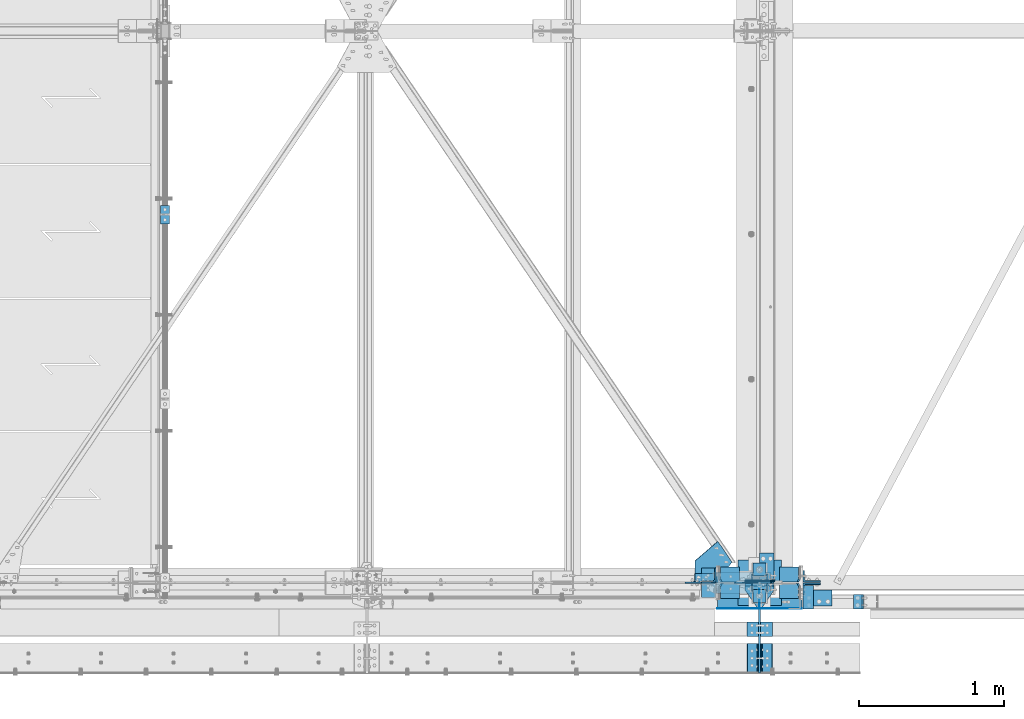
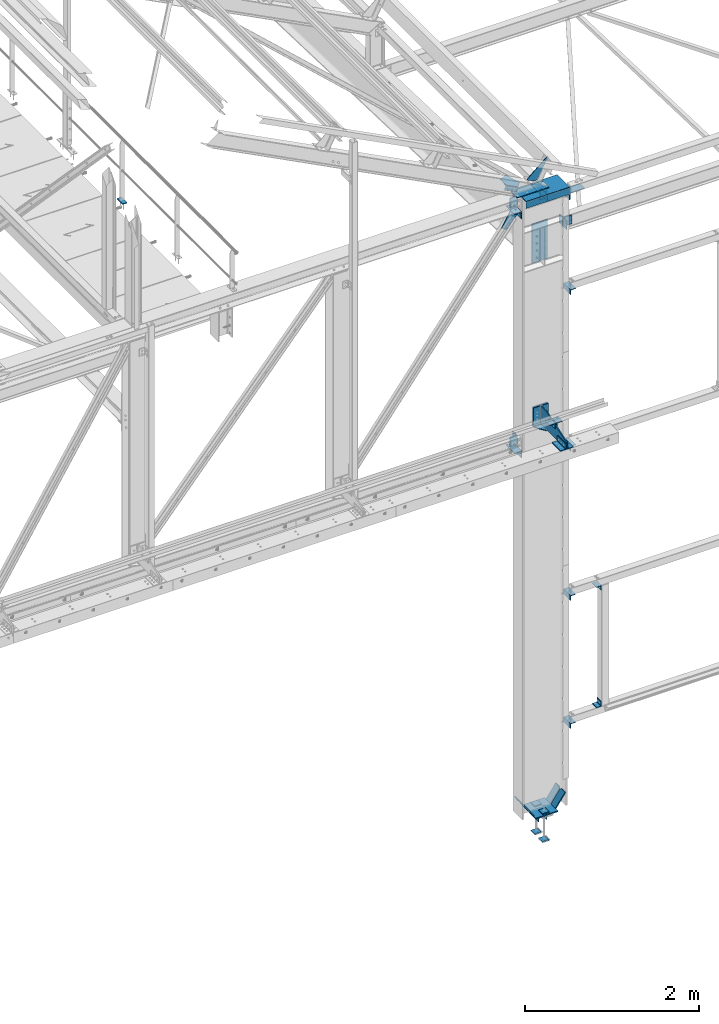
# One storey, part 87 of 496: 35 beams, 7 members, 28 elements without a shape of their own.
"""IFC2X3 building model written with IfcOpenShell, lengths in millimetres."""

from ifc_helpers import new_model, si_unit, frame, origin_with_axes, origin_2d_with_axis, place, context, subcontext, project, spatial, polyline, rectangle, i_section, l_section, outline, extrude, boolean, material, type_object, element, aggregate, save


model = new_model("IFC2X3")

# Units and contexts
model_context = context("Model", 3, precision=1e-05, world=origin_with_axes())
body_context = subcontext(model_context, "Body", "Model", "MODEL_VIEW")
ifc_project = project(units=[si_unit("LENGTHUNIT", "METRE", prefix="MILLI"), si_unit("AREAUNIT", "SQUARE_METRE"), si_unit("VOLUMEUNIT", "CUBIC_METRE"), si_unit("MASSUNIT", "GRAM", prefix="KILO"), si_unit("TIMEUNIT", "SECOND"), si_unit("PLANEANGLEUNIT", "RADIAN"), si_unit("SOLIDANGLEUNIT", "STERADIAN"), si_unit("THERMODYNAMICTEMPERATUREUNIT", "DEGREE_CELSIUS"), si_unit("LUMINOUSINTENSITYUNIT", "LUMEN")], contexts=[model_context])

# Site, building, storey
site_placement = place(None, origin_with_axes())
site = spatial("IfcSite", under=ifc_project, at=site_placement, CompositionType="ELEMENT")
building_placement = place(site_placement, origin_with_axes())
building = spatial("IfcBuilding", under=site, at=building_placement, Name="Undefined", CompositionType="ELEMENT")
storey_placement = place(building_placement, origin_with_axes())
storey = spatial("IfcBuildingStorey", under=building, at=storey_placement, Name="Undefined", CompositionType="ELEMENT", Elevation=0.0)

# Assembly, beam
assembly_1_placement = place(storey_placement, origin_with_axes())
assembly_1 = element("IfcElementAssembly", 1, at=assembly_1_placement, inside=storey, Name="MAIN COURANTE", AssemblyPlace="NOTDEFINED", PredefinedType="NOTDEFINED")
ifc_material_1 = material(Name="Undefined/S235-E24")
beam_type_1 = type_object("IfcBeamType", PredefinedType="NOTDEFINED")
beam_1_placement = place(assembly_1_placement, frame((24783.9915997864, 2600.00343957572, 8245.00000732384), z_axis=(-1.0, 0.0, 0.0), x_axis=(0.0, -1.0, 0.0)))
beam_1 = element("IfcBeam", 2, at=beam_1_placement, type_object=beam_type_1, material=ifc_material_1, context=body_context, shape_type="SweptSolid", body=[
    extrude(rectangle(XDim=10.0, YDim=60.0, at=origin_2d_with_axis()), frame((130.0, 0.0, 0.0), z_axis=(-1.0, 0.0, 0.0), x_axis=(0.0, -1.0, 0.0)), (0.0, 0.0, 1.0), 130.0),
])
aggregate(assembly_1, [beam_1])

assembly_2_placement = place(storey_placement, origin_with_axes())
assembly_2 = element("IfcElementAssembly", 3, at=assembly_2_placement, inside=storey, Name="CONTRE", AssemblyPlace="NOTDEFINED", PredefinedType="NOTDEFINED")
beam_type_2 = type_object("IfcBeamType", PredefinedType="NOTDEFINED")
beam_2_placement = place(assembly_2_placement, frame((28880.0, 11.0084493474315, 5479.99824538435), z_axis=(1.0, 0.0, 0.0), x_axis=(0.0, 0.0, -1.0)))
beam_2 = element("IfcBeam", 4, at=beam_2_placement, type_object=beam_type_2, material=ifc_material_1, Name="CONTRE", context=body_context, shape_type="SweptSolid", body=[
    extrude(rectangle(XDim=10.0, YDim=200.0, at=origin_2d_with_axis()), frame((264.997552749181, 0.0, 0.0), z_axis=(-1.0, 0.0, 0.0), x_axis=(0.0, -1.0, 0.0)), (0.0, 0.0, 1.0), 265.0),
])
aggregate(assembly_2, [beam_2])

assembly_3_placement = place(storey_placement, origin_with_axes())
assembly_3 = element("IfcElementAssembly", 5, at=assembly_3_placement, inside=storey, AssemblyPlace="NOTDEFINED", PredefinedType="NOTDEFINED")
beam_type_3 = type_object("IfcBeamType", PredefinedType="NOTDEFINED")
beam_3_placement = place(assembly_3_placement, frame((28927.4921676285, -270.0, 5409.99824538435), z_axis=(0.0, 0.0, -1.0), x_axis=(0.0, -1.0, 0.0)))
beam_3 = element("IfcBeam", 6, at=beam_3_placement, type_object=beam_type_3, material=ifc_material_1, context=body_context, shape_type="SweptSolid", body=[
    extrude(l_section(Depth=80.0, Width=80.0, Thickness=8.0, FilletRadius=10.0, EdgeRadius=5.0, at=origin_2d_with_axis()), frame((100.000000000021, 5.72981662116945e-11, -4.09272615797818e-12), z_axis=(-1.0, 0.0, 0.0), x_axis=(0.0, -1.0, 0.0)), (0.0, 0.0, 1.0), 100.0),
])
aggregate(assembly_3, [beam_3])

assembly_4_placement = place(storey_placement, origin_with_axes())
assembly_4 = element("IfcElementAssembly", 7, at=assembly_4_placement, inside=storey, AssemblyPlace="NOTDEFINED", PredefinedType="NOTDEFINED")
beam_4_placement = place(assembly_4_placement, frame((28832.5, -370.0, 5409.99824538435), z_axis=(0.0, 0.0, -1.0), x_axis=(0.0, 1.0, 0.0)))
beam_4 = element("IfcBeam", 8, at=beam_4_placement, type_object=beam_type_3, material=ifc_material_1, context=body_context, shape_type="SweptSolid", body=[
    extrude(l_section(Depth=80.0, Width=80.0, Thickness=8.0, FilletRadius=10.0, EdgeRadius=5.0, at=origin_2d_with_axis()), frame((100.000000000021, 5.72981662116945e-11, -4.09272615797818e-12), z_axis=(-1.0, 0.0, 0.0), x_axis=(0.0, -1.0, 0.0)), (0.0, 0.0, 1.0), 100.0),
])
aggregate(assembly_4, [beam_4])

assembly_5_placement = place(storey_placement, origin_with_axes())
assembly_5 = element("IfcElementAssembly", 9, at=assembly_5_placement, inside=storey, AssemblyPlace="NOTDEFINED", PredefinedType="NOTDEFINED")
beam_5_placement = place(assembly_5_placement, frame((28927.4921676285, -620.0, 5269.99824538435), z_axis=(0.0, 0.0, 1.0), x_axis=(0.0, 1.0, 0.0)))
beam_5 = element("IfcBeam", 10, at=beam_5_placement, type_object=beam_type_3, material=ifc_material_1, context=body_context, shape_type="SweptSolid", body=[
    extrude(l_section(Depth=80.0, Width=80.0, Thickness=8.0, FilletRadius=10.0, EdgeRadius=5.0, at=origin_2d_with_axis()), frame((200.0, 0.0, 0.0), z_axis=(-1.0, 0.0, 0.0), x_axis=(0.0, -1.0, 0.0)), (0.0, 0.0, 1.0), 200.0),
])
aggregate(assembly_5, [beam_5])

assembly_6_placement = place(storey_placement, origin_with_axes())
assembly_6 = element("IfcElementAssembly", 11, at=assembly_6_placement, inside=storey, AssemblyPlace="NOTDEFINED", PredefinedType="NOTDEFINED")
beam_6_placement = place(assembly_6_placement, frame((28832.5, -420.0, 5269.99824538435), z_axis=(0.0, 0.0, 1.0), x_axis=(0.0, -1.0, 0.0)))
beam_6 = element("IfcBeam", 12, at=beam_6_placement, type_object=beam_type_3, material=ifc_material_1, context=body_context, shape_type="SweptSolid", body=[
    extrude(l_section(Depth=80.0, Width=80.0, Thickness=8.0, FilletRadius=10.0, EdgeRadius=5.0, at=origin_2d_with_axis()), frame((200.0, 0.0, 0.0), z_axis=(-1.0, 0.0, 0.0), x_axis=(0.0, -1.0, 0.0)), (0.0, 0.0, 1.0), 200.0),
])
aggregate(assembly_6, [beam_6])

# Assembly, beams
assembly_7_placement = place(storey_placement, origin_with_axes())
assembly_7 = element("IfcElementAssembly", 13, at=assembly_7_placement, inside=storey, Name="CONSOLE", AssemblyPlace="NOTDEFINED", PredefinedType="NOTDEFINED")
beam_type_4 = type_object("IfcBeamType", PredefinedType="NOTDEFINED")
beam_7_placement = place(assembly_7_placement, frame((28780.0, -20.9999999999999, 5224.99824534403), z_axis=(0.0, 0.0, 1.0), x_axis=(0.0, -1.0, 0.0)))
beam_7 = element("IfcBeam", 14, at=beam_7_placement, type_object=beam_type_4, material=ifc_material_1, context=body_context, shape_type="SweptSolid", body=[
    extrude(outline(polyline([(0.0, 0.0), (30.0, 0.0), (149.0, 82.5), (149.0, 117.5), (30.0, 200.0), (0.0, 200.0), (0.0, 0.0)])), frame((0.0, 0.0, -5.0), z_axis=(0.0, 0.0, 1.0), x_axis=(1.0, 0.0, 0.0)), (0.0, 0.0, 1.0), 10.0),
])
beam_type_5 = type_object("IfcBeamType", PredefinedType="NOTDEFINED")
beam_8_placement = place(assembly_7_placement, frame((28880.0, -13.4999999999999, 5479.99824538435), z_axis=(1.0, 0.0, 0.0), x_axis=(0.0, 0.0, -1.0)))
beam_8 = element("IfcBeam", 15, at=beam_8_placement, type_object=beam_type_5, material=ifc_material_1, context=body_context, shape_type="SweptSolid", body=[
    extrude(rectangle(XDim=15.0, YDim=200.0, at=origin_2d_with_axis()), frame((264.997552749181, 0.0, 0.0), z_axis=(-1.0, 0.0, 0.0), x_axis=(0.0, -1.0, 0.0)), (0.0, 0.0, 1.0), 265.0),
])
beam_type_6 = type_object("IfcBeamType", PredefinedType="NOTDEFINED")
beam_9_placement = place(assembly_7_placement, frame((28880.0, -620.0, 5229.99824538435), z_axis=(-1.0, 0.0, 0.0), x_axis=(0.0, 0.0, 1.0)))
beam_9 = element("IfcBeam", 16, at=beam_9_placement, type_object=beam_type_6, material=ifc_material_1, Name="CONSOLE", context=body_context, shape_type="SweptSolid", body=[
    extrude(outline(polyline([(0.0, 0.0), (100.0, 0.0), (250.0, 450.0), (250.0, 599.0), (19.9999999424381, 599.0), (-5.56399857962367e-08, 579.0), (0.0, 0.0)])), frame((0.0, 0.0, -7.5), z_axis=(0.0, 0.0, 1.0), x_axis=(1.0, 0.0, 0.0)), (0.0, 0.0, 1.0), 15.0),
])
aggregate(assembly_7, [beam_7, beam_8, beam_9])

# Assembly, beam
assembly_8_placement = place(storey_placement, origin_with_axes())
assembly_8 = element("IfcElementAssembly", 17, at=assembly_8_placement, inside=storey, AssemblyPlace="NOTDEFINED", PredefinedType="NOTDEFINED")
beam_type_7 = type_object("IfcBeamType", PredefinedType="NOTDEFINED")
beam_10_placement = place(assembly_8_placement, frame((29215.0012714194, -20.0000002019504, 964.996098044679), z_axis=(0.0, 0.0, -1.0), x_axis=(0.0, -1.0, 0.0)))
beam_10 = element("IfcBeam", 18, at=beam_10_placement, type_object=beam_type_7, material=ifc_material_1, context=body_context, shape_type="SweptSolid", body=[
    extrude(l_section(Depth=70.0, Width=70.0, Thickness=7.0, FilletRadius=9.0, EdgeRadius=4.5, at=origin_2d_with_axis()), frame((160.000008264571, 0.0, 0.0), z_axis=(-1.0, 0.0, 0.0), x_axis=(0.0, -1.0, 0.0)), (0.0, 0.0, 1.0), 160.0),
])
aggregate(assembly_8, [beam_10])

assembly_9_placement = place(storey_placement, origin_with_axes())
assembly_9 = element("IfcElementAssembly", 19, at=assembly_9_placement, inside=storey, AssemblyPlace="NOTDEFINED", PredefinedType="NOTDEFINED")
beam_11_placement = place(assembly_9_placement, frame((29215.0012287166, -20.0000002019504, 7064.99609804556), z_axis=(0.0, 0.0, -1.0), x_axis=(0.0, -1.0, 0.0)))
beam_11 = element("IfcBeam", 20, at=beam_11_placement, type_object=beam_type_7, material=ifc_material_1, context=body_context, shape_type="SweptSolid", body=[
    extrude(l_section(Depth=70.0, Width=70.0, Thickness=7.0, FilletRadius=9.0, EdgeRadius=4.5, at=origin_2d_with_axis()), frame((160.000008264571, 0.0, 0.0), z_axis=(-1.0, 0.0, 0.0), x_axis=(0.0, -1.0, 0.0)), (0.0, 0.0, 1.0), 160.0),
])
aggregate(assembly_9, [beam_11])

assembly_10_placement = place(storey_placement, origin_with_axes())
assembly_10 = element("IfcElementAssembly", 21, at=assembly_10_placement, inside=storey, AssemblyPlace="NOTDEFINED", PredefinedType="NOTDEFINED")
beam_12_placement = place(assembly_10_placement, frame((29215.0012588166, -20.0000002019504, 2764.99609804556), z_axis=(0.0, 0.0, -1.0), x_axis=(0.0, -1.0, 0.0)))
beam_12 = element("IfcBeam", 22, at=beam_12_placement, type_object=beam_type_7, material=ifc_material_1, context=body_context, shape_type="SweptSolid", body=[
    extrude(l_section(Depth=70.0, Width=70.0, Thickness=7.0, FilletRadius=9.0, EdgeRadius=4.5, at=origin_2d_with_axis()), frame((160.000008264571, 0.0, 0.0), z_axis=(-1.0, 0.0, 0.0), x_axis=(0.0, -1.0, 0.0)), (0.0, 0.0, 1.0), 160.0),
])
aggregate(assembly_10, [beam_12])

assembly_11_placement = place(storey_placement, origin_with_axes())
assembly_11 = element("IfcElementAssembly", 23, at=assembly_11_placement, inside=storey, AssemblyPlace="NOTDEFINED", PredefinedType="NOTDEFINED")
beam_13_placement = place(assembly_11_placement, frame((29215.0012588166, -20.0000002019504, 4864.99609804556), z_axis=(0.0, 0.0, -1.0), x_axis=(0.0, -1.0, 0.0)))
beam_13 = element("IfcBeam", 24, at=beam_13_placement, type_object=beam_type_7, material=ifc_material_1, context=body_context, shape_type="SweptSolid", body=[
    extrude(l_section(Depth=70.0, Width=70.0, Thickness=7.0, FilletRadius=9.0, EdgeRadius=4.5, at=origin_2d_with_axis()), frame((160.000008264571, 0.0, 0.0), z_axis=(-1.0, 0.0, 0.0), x_axis=(0.0, -1.0, 0.0)), (0.0, 0.0, 1.0), 160.0),
])
aggregate(assembly_11, [beam_13])

assembly_12_placement = place(storey_placement, origin_with_axes())
assembly_12 = element("IfcElementAssembly", 25, at=assembly_12_placement, inside=storey, AssemblyPlace="NOTDEFINED", PredefinedType="NOTDEFINED")
beam_14_placement = place(assembly_12_placement, frame((29559.999999988, -80.0000086005748, 1135.0), z_axis=(0.0, 0.0, 1.0), x_axis=(0.0, -1.0, 0.0)))
beam_14 = element("IfcBeam", 26, at=beam_14_placement, type_object=beam_type_7, material=ifc_material_1, context=body_context, shape_type="SweptSolid", body=[
    extrude(l_section(Depth=70.0, Width=70.0, Thickness=7.0, FilletRadius=9.0, EdgeRadius=4.5, at=origin_2d_with_axis()), frame((100.000000000021, 5.72981662116945e-11, -4.09272615797818e-12), z_axis=(-1.0, 0.0, 0.0), x_axis=(0.0, -1.0, 0.0)), (0.0, 0.0, 1.0), 100.0),
])
aggregate(assembly_12, [beam_14])

assembly_13_placement = place(storey_placement, origin_with_axes())
assembly_13 = element("IfcElementAssembly", 27, at=assembly_13_placement, inside=storey, AssemblyPlace="NOTDEFINED", PredefinedType="NOTDEFINED")
beam_15_placement = place(assembly_13_placement, frame((29560.000000988, -180.000008614613, 2765.0), z_axis=(0.0, 0.0, -1.0), x_axis=(0.0, 1.0, 0.0)))
beam_15 = element("IfcBeam", 28, at=beam_15_placement, type_object=beam_type_7, material=ifc_material_1, context=body_context, shape_type="SweptSolid", body=[
    extrude(l_section(Depth=70.0, Width=70.0, Thickness=7.0, FilletRadius=9.0, EdgeRadius=4.5, at=origin_2d_with_axis()), frame((100.000000000021, 5.72981662116945e-11, -4.09272615797818e-12), z_axis=(-1.0, 0.0, 0.0), x_axis=(0.0, -1.0, 0.0)), (0.0, 0.0, 1.0), 100.0),
])
aggregate(assembly_13, [beam_15])

# Assembly, member
assembly_14_placement = place(storey_placement, origin_with_axes())
assembly_14 = element("IfcElementAssembly", 29, at=assembly_14_placement, inside=storey, AssemblyPlace="NOTDEFINED", PredefinedType="NOTDEFINED")
member_type_1 = type_object("IfcMemberType", PredefinedType="NOTDEFINED")
member_1_placement = place(assembly_14_placement, frame((28579.3252498457, 33.0001377978096, 8604.45371099686), z_axis=(0.0, 1.0, 0.0), x_axis=(-0.887870970350137, -2.80000019972605e-08, 0.460092534181446)))
member_1 = element("IfcMember", 30, at=member_1_placement, type_object=member_type_1, material=ifc_material_1, context=body_context, shape_type="SweptSolid", body=[
    extrude(l_section(Depth=60.0, Width=60.0, Thickness=6.0, FilletRadius=8.0, EdgeRadius=4.0, at=origin_2d_with_axis()), frame((180.0, 0.0, 0.0), z_axis=(-1.0, 0.0, 0.0), x_axis=(0.0, -1.0, 0.0)), (0.0, 0.0, 1.0), 180.0),
])
aggregate(assembly_14, [member_1])

# Assembly, beam
assembly_15_placement = place(storey_placement, origin_with_axes())
assembly_15 = element("IfcElementAssembly", 31, at=assembly_15_placement, inside=storey, Name="SHED", AssemblyPlace="NOTDEFINED", PredefinedType="NOTDEFINED")
beam_type_8 = type_object("IfcBeamType", PredefinedType="NOTDEFINED")
beam_16_placement = place(assembly_15_placement, frame((28714.4895719006, 0.0, 8721.3758937839), z_axis=(0.0, -1.0, 0.0), x_axis=(-0.460093241820242, 0.0, -0.887870603653112)))
beam_16 = element("IfcBeam", 32, at=beam_16_placement, type_object=beam_type_8, material=ifc_material_1, context=body_context, shape_type="SweptSolid", body=[
    extrude(outline(polyline([(0.0, 0.0), (20.0, 0.0), (20.0000000002019, 109.999999999982), (-9.99999999974731, 139.99998998623), (-300.0000000002, 139.999893186625), (-300.000000000226, 119.999893186643), (0.0, 0.0)])), frame((0.0, 0.0, -4.0), z_axis=(0.0, 0.0, 1.0), x_axis=(1.0, 0.0, 0.0)), (0.0, 0.0, 1.0), 8.0),
])
aggregate(assembly_15, [beam_16])

assembly_16_placement = place(storey_placement, origin_with_axes())
assembly_16 = element("IfcElementAssembly", 33, at=assembly_16_placement, inside=storey, AssemblyPlace="NOTDEFINED", PredefinedType="NOTDEFINED")
beam_type_9 = type_object("IfcBeamType", PredefinedType="NOTDEFINED")
beam_17_placement = place(assembly_16_placement, frame((29280.0031155658, -159.989858491889, 8399.99872306502), z_axis=(0.999999994849078, 0.000101497999992432, 0.0), x_axis=(-0.000101497999992439, 0.999999994849078, 0.0)))
beam_17 = element("IfcBeam", 34, at=beam_17_placement, type_object=beam_type_9, material=ifc_material_1, context=body_context, shape_type="SweptSolid", body=[
    extrude(l_section(Depth=200.0, Width=100.0, Thickness=10.0, FilletRadius=15.0, EdgeRadius=7.5, at=origin_2d_with_axis()), frame((109.999999008529, 1.81898940354586e-12, 0.0), z_axis=(-1.0, 0.0, 0.0), x_axis=(0.0, -1.0, 0.0)), (0.0, 0.0, 1.0), 110.0),
])
aggregate(assembly_16, [beam_17])

assembly_17_placement = place(storey_placement, origin_with_axes())
assembly_17 = element("IfcElementAssembly", 35, at=assembly_17_placement, inside=storey, AssemblyPlace="NOTDEFINED", PredefinedType="NOTDEFINED")
beam_18_placement = place(assembly_17_placement, frame((28980.0, 106.0, 8400.0), z_axis=(0.0, 1.0, 0.0), x_axis=(-1.0, 0.0, 0.0)))
beam_18 = element("IfcBeam", 36, at=beam_18_placement, type_object=beam_type_9, material=ifc_material_1, context=body_context, shape_type="SweptSolid", body=[
    extrude(l_section(Depth=200.0, Width=100.0, Thickness=10.0, FilletRadius=15.0, EdgeRadius=7.5, at=origin_2d_with_axis()), frame((100.000000000021, 5.72981662116945e-11, -4.09272615797818e-12), z_axis=(-1.0, 0.0, 0.0), x_axis=(0.0, -1.0, 0.0)), (0.0, 0.0, 1.0), 100.0),
])
aggregate(assembly_17, [beam_18])

assembly_18_placement = place(storey_placement, origin_with_axes())
assembly_18 = element("IfcElementAssembly", 37, at=assembly_18_placement, inside=storey, Name="TRAVERSE", AssemblyPlace="NOTDEFINED", PredefinedType="NOTDEFINED")
beam_type_10 = type_object("IfcBeamType", PredefinedType="NOTDEFINED")
beam_19_placement = place(assembly_18_placement, frame((28880.0, 13.5, 8049.34004841314), z_axis=(-1.0, 0.0, 0.0), x_axis=(0.0, 0.0, -1.0)))
beam_19 = element("IfcBeam", 38, at=beam_19_placement, type_object=beam_type_10, material=ifc_material_1, context=body_context, shape_type="SweptSolid", body=[
    extrude(rectangle(XDim=15.0, YDim=210.0, at=origin_2d_with_axis()), frame((550.00003132, 0.0, 0.0), z_axis=(-1.0, 0.0, 0.0), x_axis=(0.0, -1.0, 0.0)), (0.0, 0.0, 1.0), 550.0),
])
aggregate(assembly_18, [beam_19])

assembly_19_placement = place(storey_placement, origin_with_axes())
assembly_19 = element("IfcElementAssembly", 39, at=assembly_19_placement, inside=storey, AssemblyPlace="NOTDEFINED", PredefinedType="NOTDEFINED")
beam_type_11 = type_object("IfcBeamType", PredefinedType="NOTDEFINED")
beam_20_placement = place(assembly_19_placement, frame((28591.4170141715, 285.322059221975, 8635.3552464622), z_axis=(-0.460093241820242, 0.0, -0.887870603653112), x_axis=(0.538249849949882, -0.795292763925977, -0.278920272974034)))
beam_20 = element("IfcBeam", 40, at=beam_20_placement, type_object=beam_type_11, material=ifc_material_1, context=body_context, shape_type="SweptSolid", body=[
    extrude(outline(polyline([(0.0, 0.0), (180.000000001455, -5.27506927028298e-10), (218.686340331524, 162.319595336492), (109.565696714972, 305.472290039921), (-9.36748074309435e-06, 221.953918457995), (0.0, 0.0)])), frame((0.0, 0.0, -3.0), z_axis=(0.0, 0.0, 1.0), x_axis=(1.0, 0.0, 0.0)), (0.0, 0.0, 1.0), 6.0),
])
aggregate(assembly_19, [beam_20])

assembly_20_placement = place(storey_placement, origin_with_axes())
assembly_20 = element("IfcElementAssembly", 41, at=assembly_20_placement, inside=storey, Name="TRAVERSE SHED", AssemblyPlace="NOTDEFINED", PredefinedType="NOTDEFINED")
beam_type_12 = type_object("IfcBeamType", PredefinedType="NOTDEFINED")
beam_21_placement = place(assembly_20_placement, frame((28743.3573802739, 74.9996843547758, 8554.99999999943), z_axis=(-1.0, 0.0, 0.0), x_axis=(0.0, -1.0, 0.0)))
beam_21 = element("IfcBeam", 42, at=beam_21_placement, type_object=beam_type_12, material=ifc_material_1, context=body_context, shape_type="SweptSolid", body=[
    extrude(rectangle(XDim=10.0, YDim=420.0, at=origin_2d_with_axis()), frame((149.999995982835, 4.54747350886464e-12, 3.63797880709171e-12), z_axis=(-1.0, 0.0, 0.0), x_axis=(0.0, -1.0, 0.0)), (0.0, 0.0, 1.0), 150.0),
])
aggregate(assembly_20, [beam_21])

# Assembly, member
assembly_21_placement = place(storey_placement, origin_with_axes())
assembly_21 = element("IfcElementAssembly", 43, at=assembly_21_placement, inside=storey, AssemblyPlace="NOTDEFINED", PredefinedType="NOTDEFINED")
member_type_2 = type_object("IfcMemberType", PredefinedType="NOTDEFINED")
member_2_placement = place(assembly_21_placement, frame((29240.0021442314, 41.0926894995976, 7888.6330271737), z_axis=(1.0, 0.0, 0.0), x_axis=(0.0, 0.031410887010906, 0.999506556345274)))
member_2 = element("IfcMember", 44, at=member_2_placement, type_object=member_type_2, material=ifc_material_1, context=body_context, shape_type="SweptSolid", body=[
    extrude(l_section(Depth=120.0, Width=80.0, Thickness=10.0, FilletRadius=11.0, EdgeRadius=5.5, at=origin_2d_with_axis()), frame((120.0, 0.0, 0.0), z_axis=(-1.0, 0.0, 0.0), x_axis=(0.0, -1.0, 0.0)), (0.0, 0.0, 1.0), 120.0),
])
aggregate(assembly_21, [member_2])

assembly_22_placement = place(storey_placement, origin_with_axes())
assembly_22 = element("IfcElementAssembly", 45, at=assembly_22_placement, inside=storey, AssemblyPlace="NOTDEFINED", PredefinedType="NOTDEFINED")
member_3_placement = place(assembly_22_placement, frame((29240.0021442313, -41.096389158032, 8011.27520452147), z_axis=(1.0, 0.0, 0.0), x_axis=(0.0, -0.031410887010906, -0.999506556345274)))
member_3 = element("IfcMember", 46, at=member_3_placement, type_object=member_type_2, material=ifc_material_1, context=body_context, shape_type="SweptSolid", body=[
    extrude(l_section(Depth=120.0, Width=80.0, Thickness=10.0, FilletRadius=11.0, EdgeRadius=5.5, at=origin_2d_with_axis()), frame((120.0, 0.0, 0.0), z_axis=(-1.0, 0.0, 0.0), x_axis=(0.0, -1.0, 0.0)), (0.0, 0.0, 1.0), 120.0),
])
aggregate(assembly_22, [member_3])

# Assembly, beam
assembly_23_placement = place(storey_placement, origin_with_axes())
assembly_23 = element("IfcElementAssembly", 47, at=assembly_23_placement, inside=storey, AssemblyPlace="NOTDEFINED", PredefinedType="NOTDEFINED")
beam_type_13 = type_object("IfcBeamType", PredefinedType="NOTDEFINED")
beam_22_placement = place(assembly_23_placement, frame((28529.9999062433, 53.500000000834, 8520.00002208745), z_axis=(-1.0, 0.0, 0.0), x_axis=(0.0, 0.0, -1.0)))
beam_22 = element("IfcBeam", 48, at=beam_22_placement, type_object=beam_type_13, material=ifc_material_1, context=body_context, shape_type="SweptSolid", body=[
    extrude(l_section(Depth=100.0, Width=100.0, Thickness=10.0, FilletRadius=12.0, EdgeRadius=6.0, at=origin_2d_with_axis()), frame((130.0, 0.0, 0.0), z_axis=(-1.0, 0.0, 0.0), x_axis=(0.0, -1.0, 0.0)), (0.0, 0.0, 1.0), 130.0),
])
aggregate(assembly_23, [beam_22])

assembly_24_placement = place(storey_placement, origin_with_axes())
assembly_24 = element("IfcElementAssembly", 49, at=assembly_24_placement, inside=storey, AssemblyPlace="NOTDEFINED", PredefinedType="NOTDEFINED")
beam_23_placement = place(assembly_24_placement, frame((28529.9960922515, -99.9992396415795, 8309.99916813909), z_axis=(0.0, 0.0, -1.0), x_axis=(1.5290000004067e-05, 0.999999999883108, 0.0)))
beam_23 = element("IfcBeam", 50, at=beam_23_placement, type_object=beam_type_13, material=ifc_material_1, context=body_context, shape_type="SweptSolid", body=[
    extrude(l_section(Depth=100.0, Width=100.0, Thickness=10.0, FilletRadius=12.0, EdgeRadius=6.0, at=origin_2d_with_axis()), frame((200.0, 0.0, 0.0), z_axis=(-1.0, 0.0, 0.0), x_axis=(0.0, -1.0, 0.0)), (0.0, 0.0, 1.0), 200.0),
])

assembly_25_placement = place(storey_placement, origin_with_axes())
assembly_25 = element("IfcElementAssembly", 51, at=assembly_25_placement, inside=storey, AssemblyPlace="NOTDEFINED", PredefinedType="NOTDEFINED")
beam_24_placement = place(assembly_25_placement, frame((28529.9999062433, 53.500000000834, 5160.00085394835), z_axis=(-1.0, 0.0, 0.0), x_axis=(0.0, 0.0, -1.0)))
beam_24 = element("IfcBeam", 52, at=beam_24_placement, type_object=beam_type_13, material=ifc_material_1, context=body_context, shape_type="SweptSolid", body=[
    extrude(l_section(Depth=100.0, Width=100.0, Thickness=10.0, FilletRadius=12.0, EdgeRadius=6.0, at=origin_2d_with_axis()), frame((130.0, 0.0, 0.0), z_axis=(-1.0, 0.0, 0.0), x_axis=(0.0, -1.0, 0.0)), (0.0, 0.0, 1.0), 130.0),
])
aggregate(assembly_25, [beam_24])

assembly_26_placement = place(storey_placement, origin_with_axes())
assembly_26 = element("IfcElementAssembly", 53, at=assembly_26_placement, inside=storey, AssemblyPlace="NOTDEFINED", PredefinedType="NOTDEFINED")
beam_25_placement = place(assembly_26_placement, frame((28529.9960922515, -99.9992396415795, 4950.0), z_axis=(0.0, 0.0, -1.0), x_axis=(1.5290000004067e-05, 0.999999999883108, 0.0)))
beam_25 = element("IfcBeam", 54, at=beam_25_placement, type_object=beam_type_13, material=ifc_material_1, context=body_context, shape_type="SweptSolid", body=[
    extrude(l_section(Depth=100.0, Width=100.0, Thickness=10.0, FilletRadius=12.0, EdgeRadius=6.0, at=origin_2d_with_axis()), frame((200.0, 0.0, 0.0), z_axis=(-1.0, 0.0, 0.0), x_axis=(0.0, -1.0, 0.0)), (0.0, 0.0, 1.0), 200.0),
])
aggregate(assembly_26, [beam_25])

# Beam
beam_type_14 = type_object("IfcBeamType", PredefinedType="NOTDEFINED")
beam_26_placement = place(assembly_24_placement, frame((28569.9960922468, 0.0, 8259.99916813909), z_axis=(0.0, -1.0, 0.0), x_axis=(0.0, 0.0, 1.0)))
beam_26 = element("IfcBeam", 55, at=beam_26_placement, type_object=beam_type_14, material=ifc_material_1, context=body_context, shape_type="SweptSolid", body=[
    extrude(outline(polyline([(0.0, 0.0), (70.0, 0.0), (90.0, 20.0), (90.0, 90.0), (-114.824501037598, 203.191070556641), (-163.177642822266, 139.457458496094), (0.0, 0.0)])), frame((0.0, 0.0, -4.0), z_axis=(0.0, 0.0, 1.0), x_axis=(1.0, 0.0, 0.0)), (0.0, 0.0, 1.0), 8.0),
])

aggregate(assembly_24, [beam_26, beam_23])

# Assembly, beams
assembly_27_placement = place(storey_placement, origin_with_axes())
assembly_27 = element("IfcElementAssembly", 56, at=assembly_27_placement, inside=storey, Name="PS24", AssemblyPlace="NOTDEFINED", PredefinedType="NOTDEFINED")
beam_type_15 = type_object("IfcBeamType", PredefinedType="NOTDEFINED")
beam_27_placement = place(assembly_27_placement, frame((28925.0, -45.0028495552906, -177.5), z_axis=(0.0, 0.0, 1.0), x_axis=(-1.0, 0.0, 0.0)))
beam_27 = element("IfcBeam", 57, at=beam_27_placement, type_object=beam_type_15, material=ifc_material_1, context=body_context, shape_type="SweptSolid", body=[
    extrude(outline(polyline([(0.0, 0.0), (90.0, 0.0), (90.0, 90.0), (0.0, 90.0), (0.0, 0.0)])), frame((0.0, 0.0, -7.5), z_axis=(0.0, 0.0, 1.0), x_axis=(1.0, 0.0, 0.0)), (0.0, 0.0, 1.0), 15.0),
])
beam_28_placement = place(assembly_27_placement, frame((28925.0, 134.997150444709, -177.5), z_axis=(0.0, 0.0, 1.0), x_axis=(-1.0, 0.0, 0.0)))
beam_28 = element("IfcBeam", 58, at=beam_28_placement, type_object=beam_type_15, material=ifc_material_1, context=body_context, shape_type="SweptSolid", body=[
    extrude(outline(polyline([(0.0, 0.0), (90.0, 0.0), (90.0, 90.0), (0.0, 90.0), (0.0, 0.0)])), frame((0.0, 0.0, -7.5), z_axis=(0.0, 0.0, 1.0), x_axis=(1.0, 0.0, 0.0)), (0.0, 0.0, 1.0), 15.0),
])
beam_29_placement = place(assembly_27_placement, frame((28925.0, -45.0028495552906, -572.5), z_axis=(0.0, 0.0, 1.0), x_axis=(-1.0, 0.0, 0.0)))
beam_29 = element("IfcBeam", 59, at=beam_29_placement, type_object=beam_type_15, material=ifc_material_1, context=body_context, shape_type="SweptSolid", body=[
    extrude(outline(polyline([(0.0, 0.0), (90.0, 0.0), (90.0, 90.0), (0.0, 90.0), (0.0, 0.0)])), frame((0.0, 0.0, -7.5), z_axis=(0.0, 0.0, 1.0), x_axis=(1.0, 0.0, 0.0)), (0.0, 0.0, 1.0), 15.0),
])
beam_30_placement = place(assembly_27_placement, frame((28925.0, 134.997150444709, -572.5), z_axis=(0.0, 0.0, 1.0), x_axis=(-1.0, 0.0, 0.0)))
beam_30 = element("IfcBeam", 60, at=beam_30_placement, type_object=beam_type_15, material=ifc_material_1, context=body_context, shape_type="SweptSolid", body=[
    extrude(outline(polyline([(0.0, 0.0), (90.0, 0.0), (90.0, 90.0), (0.0, 90.0), (0.0, 0.0)])), frame((0.0, 0.0, -7.5), z_axis=(0.0, 0.0, 1.0), x_axis=(1.0, 0.0, 0.0)), (0.0, 0.0, 1.0), 15.0),
])

assembly_28_placement = place(storey_placement, origin_with_axes())
assembly_28 = element("IfcElementAssembly", 61, at=assembly_28_placement, inside=storey, Name="POTEAU", AssemblyPlace="NOTDEFINED", PredefinedType="NOTDEFINED")
beam_type_16 = type_object("IfcBeamType", PredefinedType="NOTDEFINED")
beam_31_placement = place(assembly_28_placement, frame((28880.0, -6.5, 8450.0), z_axis=(-1.0, 0.0, 0.0), x_axis=(0.0, -1.0, 0.0)))
beam_31 = element("IfcBeam", 62, at=beam_31_placement, type_object=beam_type_16, material=ifc_material_1, context=body_context, shape_type="SweptSolid", body=[
    extrude(outline(polyline([(0.0, 0.0), (168.0, 0.0), (168.0, 70.0), (148.0, 90.0), (20.000000000001, 90.0), (-7.90371359471465e-08, 70.000007629249), (0.0, 0.0)])), frame((0.0, 0.0, -2.5), z_axis=(0.0, 0.0, 1.0), x_axis=(1.0, 0.0, 0.0)), (0.0, 0.0, 1.0), 5.0),
])
beam_type_17 = type_object("IfcBeamType", PredefinedType="NOTDEFINED")
beam_32_placement = place(assembly_28_placement, frame((28879.9999999836, -177.5, 8540.00000000232), z_axis=(1.0, 0.0, 0.0), x_axis=(0.0, 0.0, -1.0)))
beam_32 = element("IfcBeam", 63, at=beam_32_placement, type_object=beam_type_17, material=ifc_material_1, context=body_context, shape_type="SweptSolid", body=[
    extrude(rectangle(XDim=5.0, YDim=581.0, at=origin_2d_with_axis()), frame((90.0, 0.0, 0.0), z_axis=(-1.0, 0.0, 0.0), x_axis=(0.0, -1.0, 0.0)), (0.0, 0.0, 1.0), 90.0),
])
beam_type_18 = type_object("IfcBeamType", PredefinedType="NOTDEFINED")
beam_33_placement = place(assembly_28_placement, frame((28589.5, -35.0, 8545.0), z_axis=(0.0, 1.0, 0.0), x_axis=(1.0, 0.0, 0.0)))
beam_33 = element("IfcBeam", 64, at=beam_33_placement, type_object=beam_type_18, material=ifc_material_1, context=body_context, shape_type="SweptSolid", body=[
    extrude(rectangle(XDim=10.0, YDim=290.0, at=origin_2d_with_axis()), frame((581.0, 0.0, 0.0), z_axis=(-1.0, 0.0, 0.0), x_axis=(0.0, -1.0, 0.0)), (0.0, 0.0, 1.0), 581.0),
])

# Beam
ifc_material_2 = material(Name="Undefined/S275-E28")
beam_type_19 = type_object("IfcBeamType", Name="HEA120", PredefinedType="NOTDEFINED")
beam_34_placement = place(assembly_27_placement, frame((28879.99999991, 0.0, -210.0), z_axis=(-1.0, 0.0, 0.0), x_axis=(0.0, 0.0, -1.0)))
beam_34 = element("IfcBeam", 65, at=beam_34_placement, type_object=beam_type_19, material=ifc_material_2, ObjectType="HEA120", context=body_context, shape_type="SweptSolid", body=[
    extrude(i_section(OverallWidth=120.0, OverallDepth=114.0, WebThickness=5.0, FlangeThickness=8.0, FilletRadius=12.0, at=origin_2d_with_axis()), frame((120.0, 0.0, 0.0), z_axis=(-1.0, 0.0, 0.0), x_axis=(0.0, -1.0, 0.0)), (0.0, 0.0, 1.0), 120.0),
])

aggregate(assembly_27, [beam_34, beam_27, beam_28, beam_29, beam_30])

# Member
member_type_3 = type_object("IfcMemberType", PredefinedType="NOTDEFINED")
member_4_placement = place(assembly_28_placement, frame((29154.8763336431, 58.25, 4.33415056396631), z_axis=(0.0, 1.0, 0.0), x_axis=(-0.577886741942777, 0.0, -0.816116972919178)))
member_4 = element("IfcMember", 66, at=member_4_placement, type_object=member_type_3, material=ifc_material_1, context=body_context, shape_type="CSG", body=[
    boolean("DIFFERENCE", extrude(rectangle(XDim=15.0, YDim=103.5, at=origin_2d_with_axis()), frame((226.683191423988, -3.77503347621641e-14, 0.0), z_axis=(-1.0, 0.0, 0.0), x_axis=(0.0, -1.0, 0.0)), (0.0, 0.0, 1.0), 226.68), extrude(outline(polyline([(0.0, 0.0), (20.0, 0.0), (20.0000000083892, 20.0), (0.0, 0.0)])), frame((20.0000000094935, -10.4999999943284, -51.75), z_axis=(0.0, 1.0, 0.0), x_axis=(-1.0, 0.0, 0.0)), (0.0, 0.0, 1.0), 21.0)),
])

member_5_placement = place(assembly_28_placement, frame((29154.8763336431, -58.25, 4.33415056396631), z_axis=(0.0, 1.0, 0.0), x_axis=(-0.577886741942777, 0.0, -0.816116972919178)))
member_5 = element("IfcMember", 67, at=member_5_placement, type_object=member_type_3, material=ifc_material_1, context=body_context, shape_type="CSG", body=[
    boolean("DIFFERENCE", extrude(rectangle(XDim=15.0, YDim=103.5, at=origin_2d_with_axis()), frame((226.683191423988, -3.77503347621641e-14, 0.0), z_axis=(-1.0, 0.0, 0.0), x_axis=(0.0, -1.0, 0.0)), (0.0, 0.0, 1.0), 226.68), extrude(outline(polyline([(0.0, 0.0), (28.2842712384918, -5.68070390727371e-09), (14.1421356183728, 14.1421356144456), (0.0, 0.0)])), frame((19.9999999913595, -10.4999999943284, 51.7500000027402), z_axis=(0.0, 1.0, 0.0), x_axis=(-0.707106781368632, 1.08068498594349e-10, -0.707106781004463)), (0.0, 0.0, 1.0), 21.0)),
])

member_6_placement = place(assembly_28_placement, frame((28605.1180011955, 58.25, 4.33427348521804), z_axis=(0.0, 1.0, 0.0), x_axis=(0.57790313132773, 0.0, -0.816105367462807)))
member_6 = element("IfcMember", 68, at=member_6_placement, type_object=member_type_3, material=ifc_material_1, context=body_context, shape_type="CSG", body=[
    boolean("DIFFERENCE", extrude(rectangle(XDim=15.0, YDim=103.5, at=origin_2d_with_axis()), frame((226.686414991487, 0.0, 0.0), z_axis=(-1.0, 0.0, 0.0), x_axis=(0.0, -1.0, 0.0)), (0.0, 0.0, 1.0), 226.69), extrude(outline(polyline([(0.0, 0.0), (20.0, 0.0), (20.0000000083892, 20.0), (0.0, 0.0)])), frame((20.0000000094935, -10.4999999943284, -51.75), z_axis=(0.0, 1.0, 0.0), x_axis=(-1.0, 0.0, 0.0)), (0.0, 0.0, 1.0), 21.0)),
])

member_7_placement = place(assembly_28_placement, frame((28605.1180011955, -58.25, 4.33427348521804), z_axis=(0.0, 1.0, 0.0), x_axis=(0.57790313132773, 0.0, -0.816105367462807)))
member_7 = element("IfcMember", 69, at=member_7_placement, type_object=member_type_3, material=ifc_material_1, context=body_context, shape_type="CSG", body=[
    boolean("DIFFERENCE", extrude(rectangle(XDim=15.0, YDim=103.5, at=origin_2d_with_axis()), frame((226.686414991487, 0.0, 0.0), z_axis=(-1.0, 0.0, 0.0), x_axis=(0.0, -1.0, 0.0)), (0.0, 0.0, 1.0), 226.69), extrude(outline(polyline([(0.0, 0.0), (28.2842712384918, -5.68070390727371e-09), (14.1421356183728, 14.1421356144456), (0.0, 0.0)])), frame((19.9999999913595, -10.4999999943284, 51.7500000027402), z_axis=(0.0, 1.0, 0.0), x_axis=(-0.707106781368632, 1.08068498594349e-10, -0.707106781004463)), (0.0, 0.0, 1.0), 21.0)),
])

# Beam
beam_type_20 = type_object("IfcBeamType", PredefinedType="NOTDEFINED")
beam_35_placement = place(assembly_28_placement, frame((28880.0, 154.997150444709, -192.5), z_axis=(1.0, 0.0, 0.0), x_axis=(0.0, -1.0, 0.0)))
beam_35 = element("IfcBeam", 70, at=beam_35_placement, type_object=beam_type_20, material=ifc_material_1, context=body_context, shape_type="SweptSolid", body=[
    extrude(rectangle(XDim=15.0, YDim=300.0, at=origin_2d_with_axis()), frame((310.0, 0.0, 0.0), z_axis=(-1.0, 0.0, 0.0), x_axis=(0.0, -1.0, 0.0)), (0.0, 0.0, 1.0), 310.0),
])

aggregate(assembly_28, [beam_31, beam_32, beam_33, member_4, member_5, member_6, member_7, beam_35])

save(model, "model.ifc")
